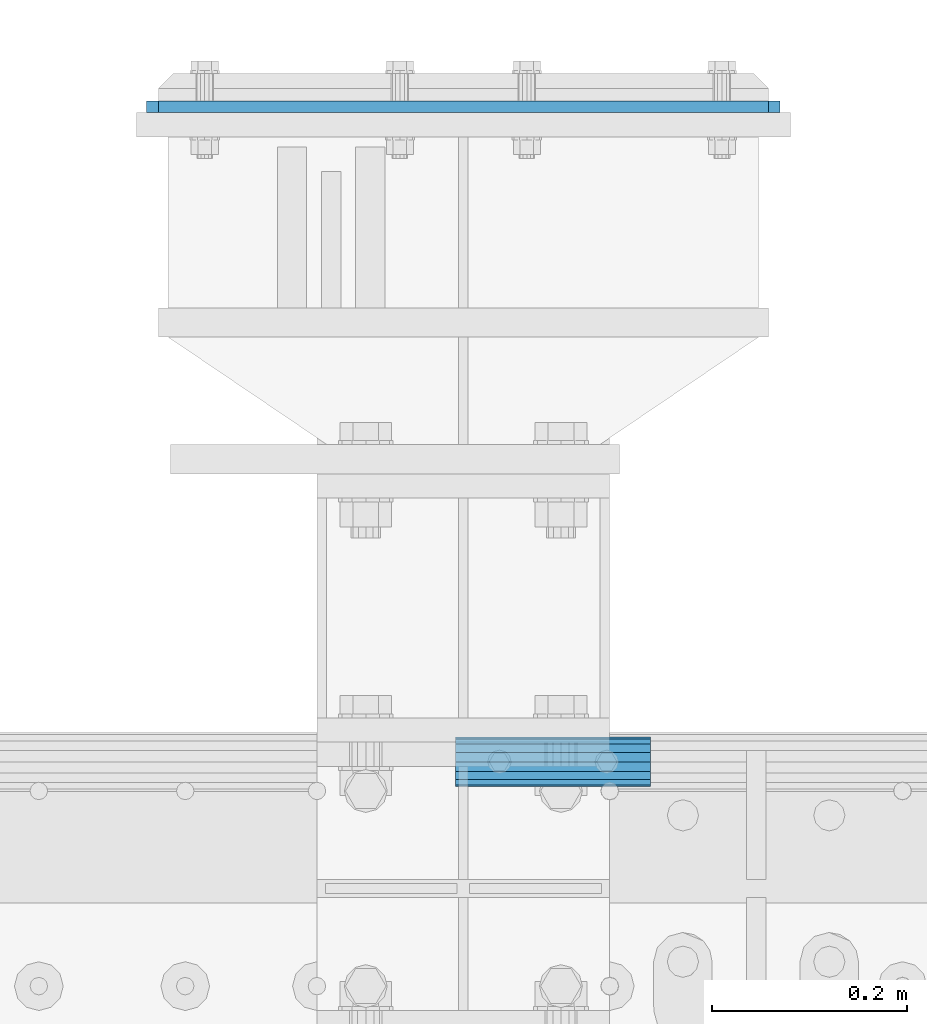
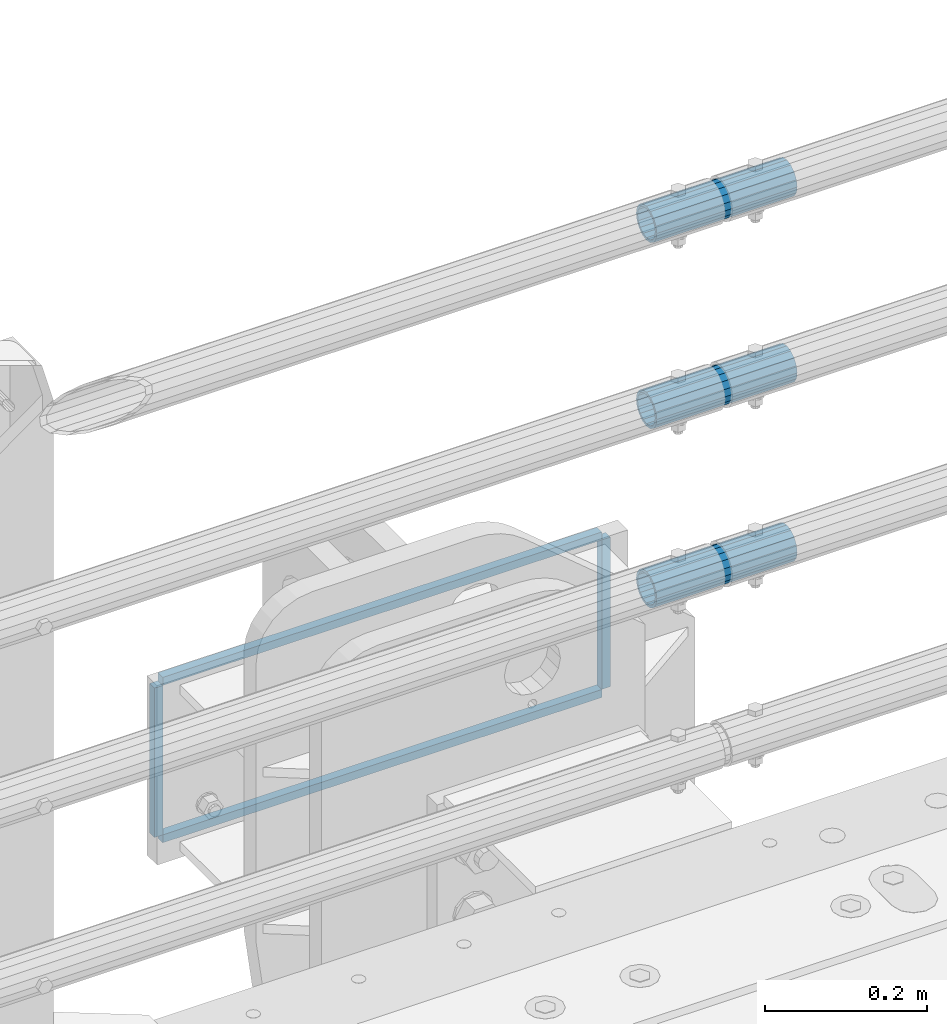
# One storey, part 170 of 270: 7 beams.
"""IFC2X3 building model written with IfcOpenShell, lengths in millimetres."""

from ifc_helpers import new_model, si_unit, frame, origin_with_axes, place, context, subcontext, project, spatial, faceted_brep, material, type_object, element, save


model = new_model("IFC2X3")

# Units and contexts
model_context = context("Model", 3, precision=1e-05, world=origin_with_axes())
body_context = subcontext(model_context, "Body", "Model", "MODEL_VIEW")
ifc_project = project(units=[si_unit("LENGTHUNIT", "METRE", prefix="MILLI"), si_unit("AREAUNIT", "SQUARE_METRE"), si_unit("VOLUMEUNIT", "CUBIC_METRE"), si_unit("MASSUNIT", "GRAM", prefix="KILO"), si_unit("TIMEUNIT", "SECOND"), si_unit("PLANEANGLEUNIT", "RADIAN"), si_unit("SOLIDANGLEUNIT", "STERADIAN"), si_unit("THERMODYNAMICTEMPERATUREUNIT", "DEGREE_CELSIUS"), si_unit("LUMINOUSINTENSITYUNIT", "LUMEN")], contexts=[model_context])

# Site, building, storey
site_placement = place(None, origin_with_axes())
site = spatial("IfcSite", under=ifc_project, at=site_placement, CompositionType="ELEMENT")
building_placement = place(site_placement, origin_with_axes())
building = spatial("IfcBuilding", under=site, at=building_placement, Name="Standard", CompositionType="ELEMENT")
storey_placement = place(building_placement, origin_with_axes())
storey = spatial("IfcBuildingStorey", under=building, at=storey_placement, Name="Undefined", CompositionType="ELEMENT", Elevation=0.0)

# Beams
ifc_material_1 = material()
beam_type_1 = type_object("IfcBeamType", PredefinedType="NOTDEFINED")
beam_1_placement = place(storey_placement, frame((14026.9975029999, -14870.1499999996, 420.149999999725), z_axis=(0.0, 0.0, 1.0), x_axis=(1.0, 0.0, 0.0)))
element("IfcBeam", 1, at=beam_1_placement, inside=storey, type_object=beam_type_1, material=ifc_material_1, context=body_context, shape_type="Brep", body=[
    faceted_brep([(0.0, -21.8999999999996, 0.0), (0.0, -20.232961761998, 8.38076716879547), (200.0, -20.232961761998, 8.38076716879547), (200.0, -21.8999999999996, 0.0), (0.0, -15.4856385079856, 15.4856385079854), (200.0, -15.4856385079856, 15.4856385079854), (0.0, -8.3807671687955, 20.2329617619972), (200.0, -8.3807671687955, 20.2329617619972), (0.0, 0.0, 21.9), (200.0, 0.0, 21.9), (0.0, 8.3807671687955, 20.2329617619972), (200.0, 8.3807671687955, 20.2329617619972), (0.0, 15.4856385079856, 15.4856385079854), (200.0, 15.4856385079856, 15.4856385079854), (0.0, 20.232961761998, 8.38076716879547), (200.0, 20.232961761998, 8.38076716879547), (0.0, 21.8999999999996, 0.0), (200.0, 21.8999999999996, 0.0), (0.0, 20.232961761998, -8.38076716879547), (200.0, 20.232961761998, -8.38076716879547), (0.0, 15.4856385079856, -15.4856385079854), (200.0, 15.4856385079856, -15.4856385079854), (0.0, 8.3807671687955, -20.2329617619972), (200.0, 8.3807671687955, -20.2329617619972), (0.0, 0.0, -21.9), (200.0, 0.0, -21.9), (0.0, -8.3807671687955, -20.2329617619972), (200.0, -8.3807671687955, -20.2329617619972), (0.0, -15.4856385079856, -15.4856385079854), (200.0, -15.4856385079856, -15.4856385079854), (0.0, -20.232961761998, -8.38076716879547), (200.0, -20.232961761998, -8.38076716879547), (0.0, -25.5, 0.0), (0.0, -23.5589280790373, -9.7584275253098), (200.0, -23.5589280790373, -9.7584275253098), (200.0, -25.5, 0.0), (0.0, -18.0312229202573, -18.031222920257), (200.0, -18.0312229202573, -18.031222920257), (0.0, -9.75842752531025, -23.5589280790378), (200.0, -9.75842752531025, -23.5589280790378), (0.0, 0.0, -25.5), (200.0, 0.0, -25.5), (0.0, 9.75842752531025, -23.5589280790378), (200.0, 9.75842752531025, -23.5589280790378), (0.0, 18.0312229202573, -18.031222920257), (200.0, 18.0312229202573, -18.031222920257), (0.0, 23.5589280790373, -9.7584275253098), (200.0, 23.5589280790373, -9.7584275253098), (0.0, 25.5, 0.0), (200.0, 25.5, 0.0), (0.0, 23.5589280790373, 9.7584275253098), (200.0, 23.5589280790373, 9.7584275253098), (0.0, 18.0312229202573, 18.031222920257), (200.0, 18.0312229202573, 18.031222920257), (0.0, 9.75842752531025, 23.5589280790378), (200.0, 9.75842752531025, 23.5589280790378), (0.0, 0.0, 25.5), (200.0, 0.0, 25.5), (0.0, -9.75842752531025, 23.5589280790378), (200.0, -9.75842752531025, 23.5589280790378), (0.0, -18.0312229202573, 18.031222920257), (200.0, -18.0312229202573, 18.031222920257), (0.0, -23.5589280790373, 9.7584275253098), (200.0, -23.5589280790373, 9.7584275253098)], [[[0, 1, 2, 3]], [[1, 4, 5, 2]], [[4, 6, 7, 5]], [[6, 8, 9, 7]], [[8, 10, 11, 9]], [[10, 12, 13, 11]], [[12, 14, 15, 13]], [[14, 16, 17, 15]], [[16, 18, 19, 17]], [[18, 20, 21, 19]], [[20, 22, 23, 21]], [[22, 24, 25, 23]], [[24, 26, 27, 25]], [[26, 28, 29, 27]], [[28, 30, 31, 29]], [[30, 0, 3, 31]], [[32, 33, 34, 35]], [[33, 36, 37, 34]], [[36, 38, 39, 37]], [[38, 40, 41, 39]], [[40, 42, 43, 41]], [[42, 44, 45, 43]], [[44, 46, 47, 45]], [[46, 48, 49, 47]], [[48, 50, 51, 49]], [[50, 52, 53, 51]], [[52, 54, 55, 53]], [[54, 56, 57, 55]], [[56, 58, 59, 57]], [[58, 60, 61, 59]], [[60, 62, 63, 61]], [[62, 32, 35, 63]], [[37, 39, 41, 43, 45, 47, 49, 51, 53, 55, 57, 59, 61, 63, 35, 34], [5, 7, 9, 11, 13, 15, 17, 19, 21, 23, 25, 27, 29, 31, 3, 2]], [[62, 60, 58, 56, 54, 52, 50, 48, 46, 44, 42, 40, 38, 36, 33, 32], [30, 28, 26, 24, 22, 20, 18, 16, 14, 12, 10, 8, 6, 4, 1, 0]]]),
])
beam_2_placement = place(storey_placement, frame((14026.9975029999, -14870.1499999996, 969.849999999726), z_axis=(0.0, 0.0, 1.0), x_axis=(1.0, 0.0, 0.0)))
element("IfcBeam", 2, at=beam_2_placement, inside=storey, type_object=beam_type_1, material=ifc_material_1, context=body_context, shape_type="Brep", body=[
    faceted_brep([(0.0, -21.8999999999996, 0.0), (0.0, -20.232961761998, 8.38076716879547), (200.0, -20.232961761998, 8.38076716879547), (200.0, -21.8999999999996, 0.0), (0.0, -15.4856385079856, 15.4856385079854), (200.0, -15.4856385079856, 15.4856385079854), (0.0, -8.3807671687955, 20.2329617619972), (200.0, -8.3807671687955, 20.2329617619972), (0.0, 0.0, 21.9), (200.0, 0.0, 21.9), (0.0, 8.3807671687955, 20.2329617619972), (200.0, 8.3807671687955, 20.2329617619972), (0.0, 15.4856385079856, 15.4856385079854), (200.0, 15.4856385079856, 15.4856385079854), (0.0, 20.232961761998, 8.38076716879547), (200.0, 20.232961761998, 8.38076716879547), (0.0, 21.8999999999996, 0.0), (200.0, 21.8999999999996, 0.0), (0.0, 20.232961761998, -8.38076716879547), (200.0, 20.232961761998, -8.38076716879547), (0.0, 15.4856385079856, -15.4856385079854), (200.0, 15.4856385079856, -15.4856385079854), (0.0, 8.3807671687955, -20.2329617619972), (200.0, 8.3807671687955, -20.2329617619972), (0.0, 0.0, -21.9), (200.0, 0.0, -21.9), (0.0, -8.3807671687955, -20.2329617619972), (200.0, -8.3807671687955, -20.2329617619972), (0.0, -15.4856385079856, -15.4856385079854), (200.0, -15.4856385079856, -15.4856385079854), (0.0, -20.232961761998, -8.38076716879547), (200.0, -20.232961761998, -8.38076716879547), (0.0, -25.5, 0.0), (0.0, -23.5589280790373, -9.7584275253098), (200.0, -23.5589280790373, -9.7584275253098), (200.0, -25.5, 0.0), (0.0, -18.0312229202573, -18.031222920257), (200.0, -18.0312229202573, -18.031222920257), (0.0, -9.75842752531025, -23.5589280790378), (200.0, -9.75842752531025, -23.5589280790378), (0.0, 0.0, -25.5), (200.0, 0.0, -25.5), (0.0, 9.75842752531025, -23.5589280790378), (200.0, 9.75842752531025, -23.5589280790378), (0.0, 18.0312229202573, -18.031222920257), (200.0, 18.0312229202573, -18.031222920257), (0.0, 23.5589280790373, -9.7584275253098), (200.0, 23.5589280790373, -9.7584275253098), (0.0, 25.5, 0.0), (200.0, 25.5, 0.0), (0.0, 23.5589280790373, 9.7584275253098), (200.0, 23.5589280790373, 9.7584275253098), (0.0, 18.0312229202573, 18.031222920257), (200.0, 18.0312229202573, 18.031222920257), (0.0, 9.75842752531025, 23.5589280790378), (200.0, 9.75842752531025, 23.5589280790378), (0.0, 0.0, 25.5), (200.0, 0.0, 25.5), (0.0, -9.75842752531025, 23.5589280790378), (200.0, -9.75842752531025, 23.5589280790378), (0.0, -18.0312229202573, 18.031222920257), (200.0, -18.0312229202573, 18.031222920257), (0.0, -23.5589280790373, 9.7584275253098), (200.0, -23.5589280790373, 9.7584275253098)], [[[0, 1, 2, 3]], [[1, 4, 5, 2]], [[4, 6, 7, 5]], [[6, 8, 9, 7]], [[8, 10, 11, 9]], [[10, 12, 13, 11]], [[12, 14, 15, 13]], [[14, 16, 17, 15]], [[16, 18, 19, 17]], [[18, 20, 21, 19]], [[20, 22, 23, 21]], [[22, 24, 25, 23]], [[24, 26, 27, 25]], [[26, 28, 29, 27]], [[28, 30, 31, 29]], [[30, 0, 3, 31]], [[32, 33, 34, 35]], [[33, 36, 37, 34]], [[36, 38, 39, 37]], [[38, 40, 41, 39]], [[40, 42, 43, 41]], [[42, 44, 45, 43]], [[44, 46, 47, 45]], [[46, 48, 49, 47]], [[48, 50, 51, 49]], [[50, 52, 53, 51]], [[52, 54, 55, 53]], [[54, 56, 57, 55]], [[56, 58, 59, 57]], [[58, 60, 61, 59]], [[60, 62, 63, 61]], [[62, 32, 35, 63]], [[37, 39, 41, 43, 45, 47, 49, 51, 53, 55, 57, 59, 61, 63, 35, 34], [5, 7, 9, 11, 13, 15, 17, 19, 21, 23, 25, 27, 29, 31, 3, 2]], [[62, 60, 58, 56, 54, 52, 50, 48, 46, 44, 42, 40, 38, 36, 33, 32], [30, 28, 26, 24, 22, 20, 18, 16, 14, 12, 10, 8, 6, 4, 1, 0]]]),
])
beam_3_placement = place(storey_placement, frame((14026.9975029999, -14870.1499999996, 689.849999999726), z_axis=(0.0, 0.0, 1.0), x_axis=(1.0, 0.0, 0.0)))
element("IfcBeam", 3, at=beam_3_placement, inside=storey, type_object=beam_type_1, material=ifc_material_1, context=body_context, shape_type="Brep", body=[
    faceted_brep([(0.0, -21.8999999999996, 0.0), (0.0, -20.232961761998, 8.38076716879547), (200.0, -20.232961761998, 8.38076716879547), (200.0, -21.8999999999996, 0.0), (0.0, -15.4856385079856, 15.4856385079854), (200.0, -15.4856385079856, 15.4856385079854), (0.0, -8.3807671687955, 20.2329617619972), (200.0, -8.3807671687955, 20.2329617619972), (0.0, 0.0, 21.9), (200.0, 0.0, 21.9), (0.0, 8.3807671687955, 20.2329617619972), (200.0, 8.3807671687955, 20.2329617619972), (0.0, 15.4856385079856, 15.4856385079854), (200.0, 15.4856385079856, 15.4856385079854), (0.0, 20.232961761998, 8.38076716879547), (200.0, 20.232961761998, 8.38076716879547), (0.0, 21.8999999999996, 0.0), (200.0, 21.8999999999996, 0.0), (0.0, 20.232961761998, -8.38076716879547), (200.0, 20.232961761998, -8.38076716879547), (0.0, 15.4856385079856, -15.4856385079854), (200.0, 15.4856385079856, -15.4856385079854), (0.0, 8.3807671687955, -20.2329617619972), (200.0, 8.3807671687955, -20.2329617619972), (0.0, 0.0, -21.9), (200.0, 0.0, -21.9), (0.0, -8.3807671687955, -20.2329617619972), (200.0, -8.3807671687955, -20.2329617619972), (0.0, -15.4856385079856, -15.4856385079854), (200.0, -15.4856385079856, -15.4856385079854), (0.0, -20.232961761998, -8.38076716879547), (200.0, -20.232961761998, -8.38076716879547), (0.0, -25.5, 0.0), (0.0, -23.5589280790373, -9.7584275253098), (200.0, -23.5589280790373, -9.7584275253098), (200.0, -25.5, 0.0), (0.0, -18.0312229202573, -18.031222920257), (200.0, -18.0312229202573, -18.031222920257), (0.0, -9.75842752531025, -23.5589280790378), (200.0, -9.75842752531025, -23.5589280790378), (0.0, 0.0, -25.5), (200.0, 0.0, -25.5), (0.0, 9.75842752531025, -23.5589280790378), (200.0, 9.75842752531025, -23.5589280790378), (0.0, 18.0312229202573, -18.031222920257), (200.0, 18.0312229202573, -18.031222920257), (0.0, 23.5589280790373, -9.7584275253098), (200.0, 23.5589280790373, -9.7584275253098), (0.0, 25.5, 0.0), (200.0, 25.5, 0.0), (0.0, 23.5589280790373, 9.7584275253098), (200.0, 23.5589280790373, 9.7584275253098), (0.0, 18.0312229202573, 18.031222920257), (200.0, 18.0312229202573, 18.031222920257), (0.0, 9.75842752531025, 23.5589280790378), (200.0, 9.75842752531025, 23.5589280790378), (0.0, 0.0, 25.5), (200.0, 0.0, 25.5), (0.0, -9.75842752531025, 23.5589280790378), (200.0, -9.75842752531025, 23.5589280790378), (0.0, -18.0312229202573, 18.031222920257), (200.0, -18.0312229202573, 18.031222920257), (0.0, -23.5589280790373, 9.7584275253098), (200.0, -23.5589280790373, 9.7584275253098)], [[[0, 1, 2, 3]], [[1, 4, 5, 2]], [[4, 6, 7, 5]], [[6, 8, 9, 7]], [[8, 10, 11, 9]], [[10, 12, 13, 11]], [[12, 14, 15, 13]], [[14, 16, 17, 15]], [[16, 18, 19, 17]], [[18, 20, 21, 19]], [[20, 22, 23, 21]], [[22, 24, 25, 23]], [[24, 26, 27, 25]], [[26, 28, 29, 27]], [[28, 30, 31, 29]], [[30, 0, 3, 31]], [[32, 33, 34, 35]], [[33, 36, 37, 34]], [[36, 38, 39, 37]], [[38, 40, 41, 39]], [[40, 42, 43, 41]], [[42, 44, 45, 43]], [[44, 46, 47, 45]], [[46, 48, 49, 47]], [[48, 50, 51, 49]], [[50, 52, 53, 51]], [[52, 54, 55, 53]], [[54, 56, 57, 55]], [[56, 58, 59, 57]], [[58, 60, 61, 59]], [[60, 62, 63, 61]], [[62, 32, 35, 63]], [[37, 39, 41, 43, 45, 47, 49, 51, 53, 55, 57, 59, 61, 63, 35, 34], [5, 7, 9, 11, 13, 15, 17, 19, 21, 23, 25, 27, 29, 31, 3, 2]], [[62, 60, 58, 56, 54, 52, 50, 48, 46, 44, 42, 40, 38, 36, 33, 32], [30, 28, 26, 24, 22, 20, 18, 16, 14, 12, 10, 8, 6, 4, 1, 0]]]),
])
ifc_material_2 = material(Name="STEEL/S355N")
beam_type_2 = type_object("IfcBeamType", PredefinedType="NOTDEFINED")
for number, where, z_axis, x_axis in (
    (4, (13716.4999999931, -14198.9999999546, -22.5000182056285), (-1.0, 0.0, 0.0), (0.0, 0.0, -1.0)),
    (5, (14353.4999999931, -14198.9999999546, -22.5000182056285), (-1.0, 0.0, 0.0), (0.0, 0.0, -1.0)),
):
    element("IfcBeam", number, at=place(storey_placement, frame(where, z_axis=z_axis, x_axis=x_axis)), inside=storey, type_object=beam_type_2, material=ifc_material_2, context=body_context, shape_type="Brep", body=[
        faceted_brep([(0.0, 6.0, -6.0), (0.0, 6.0, 6.0), (225.0, 6.0, 6.0), (225.0, 6.0, -6.0), (0.0, -6.0, 6.0), (225.0, -6.0, 6.0), (0.0, -6.0, -6.0), (225.0, -6.0, -6.0)], [[[0, 1, 2, 3]], [[1, 4, 5, 2]], [[4, 6, 7, 5]], [[6, 0, 3, 7]], [[5, 7, 3, 2]], [[6, 4, 1, 0]]]),
    ])
for number, where, z_axis, x_axis in (
    (6, (13722.4999999931, -14198.9999999546, -16.5000182056285), (0.0, 0.0, -1.0), (1.0, 0.0, 0.0)),
    (7, (13722.4999999931, -14198.9999999546, -253.500018205628), (0.0, 0.0, -1.0), (1.0, 0.0, 0.0)),
):
    element("IfcBeam", number, at=place(storey_placement, frame(where, z_axis=z_axis, x_axis=x_axis)), inside=storey, type_object=beam_type_2, material=ifc_material_2, context=body_context, shape_type="Brep", body=[
        faceted_brep([(0.0, 6.0, -6.0), (0.0, 6.0, 6.0), (625.000000001684, 6.0, 6.0), (625.000000001684, 6.0, -6.0), (0.0, -6.0, 6.0), (625.000000001684, -6.0, 6.0), (0.0, -6.0, -6.0), (625.000000001684, -6.0, -6.0)], [[[0, 1, 2, 3]], [[1, 4, 5, 2]], [[4, 6, 7, 5]], [[6, 0, 3, 7]], [[5, 7, 3, 2]], [[6, 4, 1, 0]]]),
    ])

save(model, "model.ifc")
